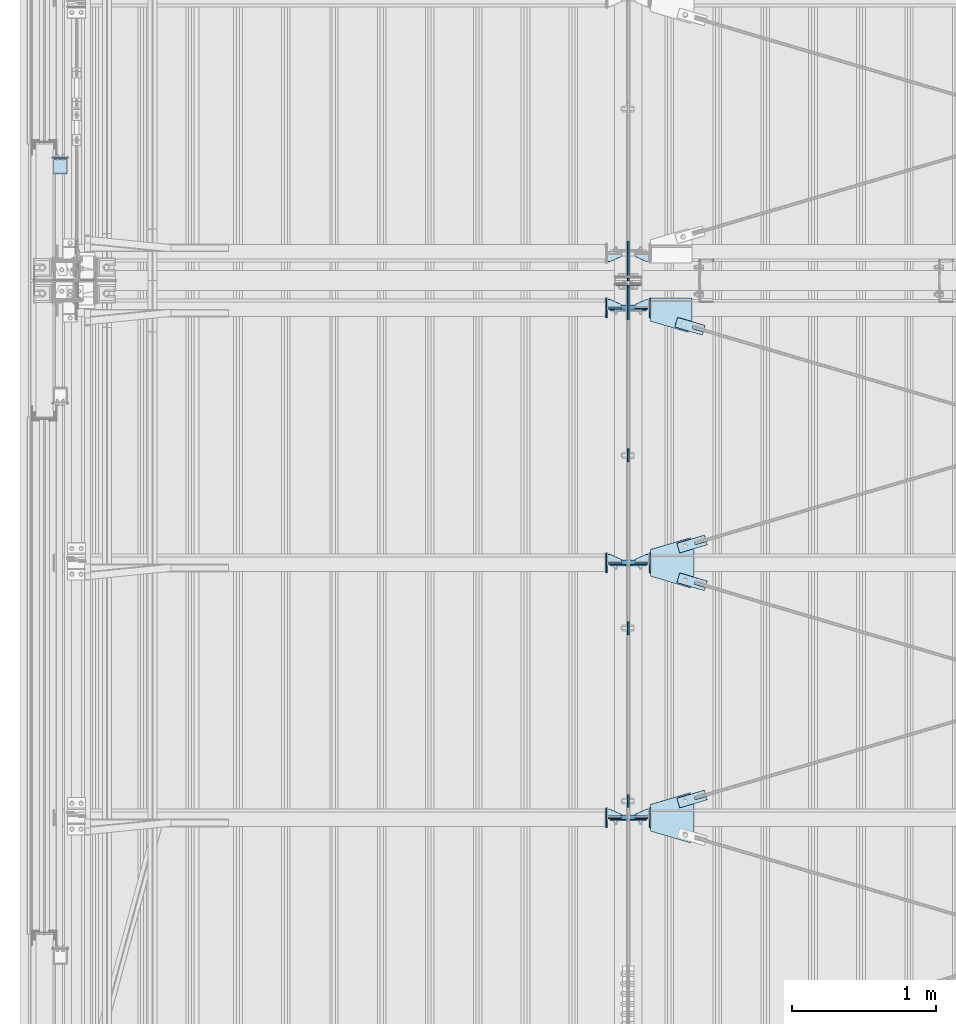
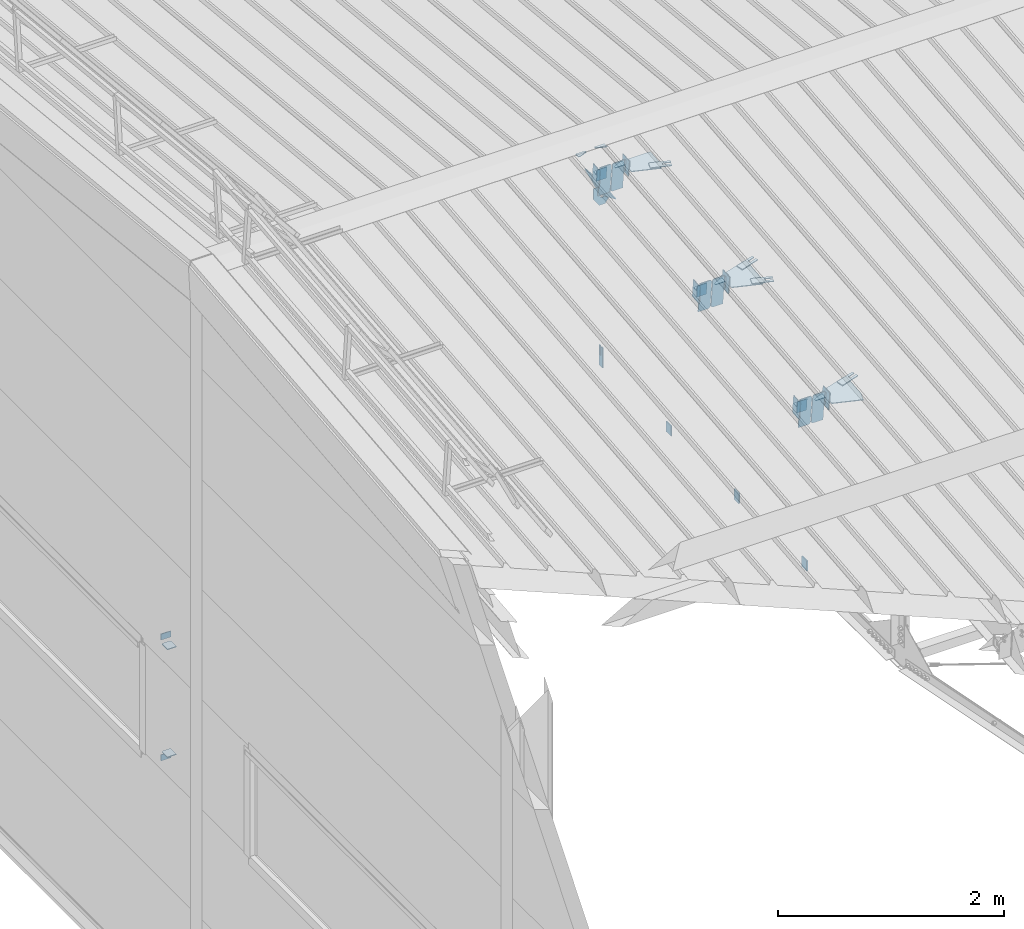
# One storey, part 117 of 709: 44 plates, 4 openings, 21 elements without a shape of their own.
"""IFC4 building model written with IfcOpenShell, lengths in millimetres."""

from ifc_helpers import new_model, si_unit, direction, frame, origin_with_axes, place, context, subcontext, project, spatial, line, indexed_curve, outline, extrude, material, element, aggregate, save


model = new_model("IFC4")

# Units and contexts
model_context = context("Model", 3, precision=0.2, world=origin_with_axes(), true_north=direction((0.0, 1.0)))
body_context = subcontext(model_context, "Body", "Model", "MODEL_VIEW")
ifc_project = project(units=[si_unit("LENGTHUNIT", "METRE", prefix="MILLI"), si_unit("AREAUNIT", "SQUARE_METRE"), si_unit("VOLUMEUNIT", "CUBIC_METRE"), si_unit("MASSUNIT", "GRAM", prefix="KILO"), si_unit("TIMEUNIT", "SECOND"), si_unit("PLANEANGLEUNIT", "RADIAN"), si_unit("SOLIDANGLEUNIT", "STERADIAN"), si_unit("THERMODYNAMICTEMPERATUREUNIT", "DEGREE_CELSIUS"), si_unit("LUMINOUSINTENSITYUNIT", "LUMEN")], contexts=[model_context])

# Site, building, storey
site_placement = place(None, origin_with_axes())
site = spatial("IfcSite", under=ifc_project, at=site_placement, CompositionType="ELEMENT")
building_placement = place(site_placement, origin_with_axes())
building = spatial("IfcBuilding", under=site, at=building_placement, Name="Undefined", CompositionType="ELEMENT")
storey_placement = place(building_placement, origin_with_axes())
storey = spatial("IfcBuildingStorey", under=building, at=storey_placement, Name="Undefined", CompositionType="ELEMENT", Elevation=0.0)

# Assembly, plates
assembly_1_placement = place(storey_placement, frame((4000.0, 346.0, 7089.70002), z_axis=(1.0, 0.0, 0.0), x_axis=(0.0, 0.9950371902, 0.099503719)))
assembly_1 = element("IfcElementAssembly", 1, at=assembly_1_placement, inside=storey)
ifc_material = material(Name="C355-6", Category="STEEL")
plate_1_placement = place(assembly_1_placement, frame((6951.14662, 163.0, -127.0), z_axis=(1.0, 0.0, 0.0), x_axis=(0.0, 0.0, 1.0)))
plate_1 = element("IfcPlate", 2, at=plate_1_placement, material=ifc_material, ObjectType="585", context=body_context, shape_type="SolidModel", body=[
    extrude(outline(indexed_curve([(0.0, 0.0), (108.0, 0.0), (123.0, 15.0), (123.0, 311.0), (108.0, 326.0), (0.0, 326.0)], segments=[line(1, 2, 3, 4, 5, 6, 1)])), frame((0.0, 0.0, 4.0), z_axis=(0.0, 0.0, 1.0), x_axis=(1.0, 0.0, 0.0)), (0.0, 0.0, -1.0), 8.0),
])
plate_2_placement = place(assembly_1_placement, frame((10515.43997, 163.0, 127.0), z_axis=(-1.0, 0.0, 0.0), x_axis=(0.0, 0.0, -1.0)))
plate_2 = element("IfcPlate", 3, at=plate_2_placement, material=ifc_material, ObjectType="589", context=body_context, shape_type="SolidModel", body=[
    extrude(outline(indexed_curve([(0.0, 0.0), (108.0, 0.0), (123.0, 15.0), (123.0, 311.0), (108.0, 326.0), (0.0, 326.0)], segments=[line(1, 2, 3, 4, 5, 6, 1)])), frame((0.0, 0.0, 4.0), z_axis=(0.0, 0.0, 1.0), x_axis=(1.0, 0.0, 0.0)), (0.0, 0.0, -1.0), 8.0),
])
plate_3_placement = place(assembly_1_placement, frame((10515.436, 163.0, -127.0), z_axis=(1.0, 0.0, 0.0), x_axis=(0.0, 0.0, 1.0)))
plate_3 = element("IfcPlate", 4, at=plate_3_placement, material=ifc_material, ObjectType="585", context=body_context, shape_type="SolidModel", body=[
    extrude(outline(indexed_curve([(0.0, 0.0), (108.0, 0.0), (123.0, 15.0), (123.0, 311.0), (108.0, 326.0), (0.0, 326.0)], segments=[line(1, 2, 3, 4, 5, 6, 1)])), frame((0.0, 0.0, 4.0), z_axis=(0.0, 0.0, 1.0), x_axis=(1.0, 0.0, 0.0)), (0.0, 0.0, -1.0), 8.0),
])
plate_4_placement = place(assembly_1_placement, frame((8733.29528, 163.0, 127.0), z_axis=(-1.0, 0.0, 0.0), x_axis=(0.0, 0.0, -1.0)))
plate_4 = element("IfcPlate", 5, at=plate_4_placement, material=ifc_material, ObjectType="585", context=body_context, shape_type="SolidModel", body=[
    extrude(outline(indexed_curve([(0.0, 0.0), (108.0, 0.0), (123.0, 15.0), (123.0, 311.0), (108.0, 326.0), (0.0, 326.0)], segments=[line(1, 2, 3, 4, 5, 6, 1)])), frame((0.0, 0.0, 4.0), z_axis=(0.0, 0.0, 1.0), x_axis=(1.0, 0.0, 0.0)), (0.0, 0.0, -1.0), 8.0),
])
plate_5_placement = place(assembly_1_placement, frame((8733.29131, 163.0, -127.0), z_axis=(1.0, 0.0, 0.0), x_axis=(0.0, 0.0, 1.0)))
plate_5 = element("IfcPlate", 6, at=plate_5_placement, material=ifc_material, ObjectType="585", context=body_context, shape_type="SolidModel", body=[
    extrude(outline(indexed_curve([(0.0, 0.0), (108.0, 0.0), (123.0, 15.0), (123.0, 311.0), (108.0, 326.0), (0.0, 326.0)], segments=[line(1, 2, 3, 4, 5, 6, 1)])), frame((0.0, 0.0, 4.0), z_axis=(0.0, 0.0, 1.0), x_axis=(1.0, 0.0, 0.0)), (0.0, 0.0, -1.0), 8.0),
])
plate_6_placement = place(assembly_1_placement, frame((6951.15059, 163.0, 127.0), z_axis=(-1.0, 0.0, 0.0), x_axis=(0.0, 0.0, -1.0)))
plate_6 = element("IfcPlate", 7, at=plate_6_placement, material=ifc_material, ObjectType="585", context=body_context, shape_type="SolidModel", body=[
    extrude(outline(indexed_curve([(0.0, 0.0), (108.0, 0.0), (123.0, 15.0), (123.0, 311.0), (108.0, 326.0), (0.0, 326.0)], segments=[line(1, 2, 3, 4, 5, 6, 1)])), frame((0.0, 0.0, 4.0), z_axis=(0.0, 0.0, 1.0), x_axis=(1.0, 0.0, 0.0)), (0.0, 0.0, -1.0), 8.0),
])
plate_7_placement = place(assembly_1_placement, frame((10651.77731, -302.35483, 0.0), z_axis=(0.0, 0.0, 1.0), x_axis=(0.099503719, 0.9950371902, 0.0)))
plate_7 = element("IfcPlate", 8, at=plate_7_placement, material=ifc_material, ObjectType="439", context=body_context, shape_type="SolidModel", body=[
    extrude(outline(indexed_curve([(0.0, 0.0), (130.0, 0.0), (105.12407, 248.7593)], segments=[line(1, 2, 3, 1)])), frame((0.0, 0.0, 6.0), z_axis=(0.0, 0.0, 1.0), x_axis=(1.0, 0.0, 0.0)), (0.0, 0.0, -1.0), 12.0),
])
aggregate(assembly_1, [plate_1, plate_2, plate_3, plate_4, plate_5, plate_6, plate_7])

# Assembly, plate
assembly_2_placement = place(storey_placement, frame((4000.0, 21654.0, 7089.70002), z_axis=(-1.0, 0.0, 0.0), x_axis=(0.0, -0.9950371902, 0.099503719)))
assembly_2 = element("IfcElementAssembly", 9, at=assembly_2_placement, inside=storey)
plate_8_placement = place(assembly_2_placement, frame((10651.77731, -302.35483, 0.0), z_axis=(0.0, 0.0, 1.0), x_axis=(0.099503719, 0.9950371902, 0.0)))
plate_8 = element("IfcPlate", 10, at=plate_8_placement, material=ifc_material, ObjectType="439", context=body_context, shape_type="SolidModel", body=[
    extrude(outline(indexed_curve([(0.0, 0.0), (130.0, 0.0), (105.12407, 248.7593)], segments=[line(1, 2, 3, 1)])), frame((0.0, 0.0, 6.0), z_axis=(0.0, 0.0, 1.0), x_axis=(1.0, 0.0, 0.0)), (0.0, 0.0, -1.0), 12.0),
])
aggregate(assembly_2, [plate_8])

# Assembly, plates
assembly_3_placement = place(storey_placement, frame((4000.0, 10985.0, 8155.10002), z_axis=(0.0, -1.0, 0.0), x_axis=(0.0, 0.0, -1.0)))
assembly_3 = element("IfcElementAssembly", 11, at=assembly_3_placement, inside=storey)
plate_9_placement = place(assembly_3_placement, frame((2165.1, 0.0, 30.0), z_axis=(0.0, 1.0, 0.0), x_axis=(0.0, 0.0, -1.0)))
plate_9 = element("IfcPlate", 12, at=plate_9_placement, material=ifc_material, ObjectType="441", context=body_context, shape_type="SolidModel", body=[
    extrude(outline(indexed_curve([(0.0, 0.0), (60.0, 0.0), (60.0, 220.0), (41.0, 220.0), (41.0, 120.0), (19.0, 120.0), (19.0, 220.0), (0.0, 220.0)], segments=[line(1, 2, 3, 4, 5, 6, 7, 8, 1)])), frame((0.0, 0.0, 6.0), z_axis=(0.0, 0.0, 1.0), x_axis=(1.0, 0.0, 0.0)), (0.0, 0.0, -1.0), 12.0),
])
plate_10_placement = place(assembly_3_placement, frame((206.36285, -87.0, 14.0), z_axis=(0.0, 0.0, -1.0), x_axis=(0.0, 1.0, 0.0)))
plate_10 = element("IfcPlate", 13, at=plate_10_placement, material=ifc_material, ObjectType="440", context=body_context, shape_type="SolidModel", body=[
    extrude(outline(indexed_curve([(0.0, 0.0), (71.0, 0.0), (71.0, 120.0), (103.0, 120.0), (103.0, 0.0), (174.0, 0.0), (174.0, 120.0), (117.0, 200.0), (57.0, 200.0), (0.0, 120.0)], segments=[line(1, 2, 3, 4, 5, 6, 7, 8, 9, 10, 1)])), frame((0.0, 0.0, 4.0), z_axis=(0.0, 0.0, 1.0), x_axis=(1.0, 0.0, 0.0)), (0.0, 0.0, -1.0), 8.0),
])
aggregate(assembly_3, [plate_9, plate_10])

# Assembly, plate
assembly_4_placement = place(storey_placement, frame((4000.0, 7334.75, 6100.00002), z_axis=(-1.0, 0.0, 0.0), x_axis=(0.0, 1.0, 0.0)))
assembly_4 = element("IfcElementAssembly", 14, at=assembly_4_placement, inside=storey)
plate_11_placement = place(assembly_4_placement, origin_with_axes())
plate_11 = element("IfcPlate", 15, at=plate_11_placement, material=ifc_material, ObjectType="491", context=body_context, shape_type="SolidModel", body=[
    extrude(outline(indexed_curve([(0.0, 0.0), (90.0, 0.0), (90.0, 110.0), (0.0, 110.0)], segments=[line(1, 2, 3, 4, 1)])), frame((0.0, 0.0, 6.0), z_axis=(0.0, 0.0, 1.0), x_axis=(1.0, 0.0, 0.0)), (0.0, 0.0, -1.0), 12.0),
])
aggregate(assembly_4, [plate_11])

assembly_5_placement = place(storey_placement, frame((4000.0, 8536.5, 6100.00002), z_axis=(-1.0, 0.0, 0.0), x_axis=(0.0, 1.0, 0.0)))
assembly_5 = element("IfcElementAssembly", 16, at=assembly_5_placement, inside=storey)
plate_12_placement = place(assembly_5_placement, origin_with_axes())
plate_12 = element("IfcPlate", 17, at=plate_12_placement, material=ifc_material, ObjectType="491", context=body_context, shape_type="SolidModel", body=[
    extrude(outline(indexed_curve([(0.0, 0.0), (90.0, 0.0), (90.0, 110.0), (0.0, 110.0)], segments=[line(1, 2, 3, 4, 1)])), frame((0.0, 0.0, 6.0), z_axis=(0.0, 0.0, 1.0), x_axis=(1.0, 0.0, 0.0)), (0.0, 0.0, -1.0), 12.0),
])
aggregate(assembly_5, [plate_12])

assembly_6_placement = place(storey_placement, frame((4000.0, 9738.25, 6100.00002), z_axis=(-1.0, 0.0, 0.0), x_axis=(0.0, 1.0, 0.0)))
assembly_6 = element("IfcElementAssembly", 18, at=assembly_6_placement, inside=storey)
plate_13_placement = place(assembly_6_placement, origin_with_axes())
plate_13 = element("IfcPlate", 19, at=plate_13_placement, material=ifc_material, ObjectType="491", context=body_context, shape_type="SolidModel", body=[
    extrude(outline(indexed_curve([(0.0, 0.0), (90.0, 0.0), (90.0, 110.0), (0.0, 110.0)], segments=[line(1, 2, 3, 4, 1)])), frame((0.0, 0.0, 6.0), z_axis=(0.0, 0.0, 1.0), x_axis=(1.0, 0.0, 0.0)), (0.0, 0.0, -1.0), 12.0),
])
aggregate(assembly_6, [plate_13])

assembly_7_placement = place(storey_placement, frame((50.0, 16500.0, 2550.0), z_axis=(0.0, 0.0, -1.0), x_axis=(0.0, -1.0, 0.0)))
assembly_7 = element("IfcElementAssembly", 20, at=assembly_7_placement, inside=storey)
plate_14_placement = place(assembly_7_placement, frame((4646.0, 50.0, -50.0), z_axis=(-1.0, 0.0, 0.0), x_axis=(0.0, 0.0, -1.0)))
plate_14 = element("IfcPlate", 21, at=plate_14_placement, material=ifc_material, ObjectType="509", context=body_context, shape_type="SolidModel", body=[
    extrude(outline(indexed_curve([(0.0, 0.0), (65.0, 0.0), (65.0, 100.0), (0.0, 100.0)], segments=[line(1, 2, 3, 4, 1)])), frame((0.0, 0.0, 4.0), z_axis=(0.0, 0.0, 1.0), x_axis=(1.0, 0.0, 0.0)), (0.0, 0.0, -1.0), 8.0),
])
aggregate(assembly_7, [plate_14])

assembly_8_placement = place(storey_placement, frame((50.0, 16500.0, 4020.0), z_axis=(0.0, 0.0, -1.0), x_axis=(0.0, -1.0, 0.0)))
assembly_8 = element("IfcElementAssembly", 22, at=assembly_8_placement, inside=storey)
plate_15_placement = place(assembly_8_placement, frame((4646.0, -50.0, 50.0), z_axis=(-1.0, 0.0, 0.0), x_axis=(0.0, 0.0, 1.0)))
plate_15 = element("IfcPlate", 23, at=plate_15_placement, material=ifc_material, ObjectType="509", context=body_context, shape_type="SolidModel", body=[
    extrude(outline(indexed_curve([(0.0, 0.0), (65.0, 0.0), (65.0, 100.0), (0.0, 100.0)], segments=[line(1, 2, 3, 4, 1)])), frame((0.0, 0.0, 4.0), z_axis=(0.0, 0.0, 1.0), x_axis=(1.0, 0.0, 0.0)), (0.0, 0.0, -1.0), 8.0),
])
aggregate(assembly_8, [plate_15])

# Assembly, plates
assembly_9_placement = place(storey_placement, frame((50.0, 11800.0, 2600.0), z_axis=(0.0, -1.0, 0.0), x_axis=(0.0, 0.0, 1.0)))
assembly_9 = element("IfcElementAssembly", 24, at=assembly_9_placement, inside=storey)
plate_16_placement = place(assembly_9_placement, frame((1267.0, -46.0, -46.0), z_axis=(1.0, 0.0, 0.0), x_axis=(0.0, 1.0, 0.0)))
plate_16 = element("IfcPlate", 25, at=plate_16_placement, material=ifc_material, ObjectType="510", context=body_context, shape_type="SolidModel", body=[
    extrude(outline(indexed_curve([(0.0, 10.0), (10.0, 0.0), (82.0, 0.0), (92.0, 10.0), (92.0, 104.0), (0.0, 104.0)], segments=[line(1, 2, 3, 4, 5, 6, 1)])), frame((0.0, 0.0, 4.0), z_axis=(0.0, 0.0, 1.0), x_axis=(1.0, 0.0, 0.0)), (0.0, 0.0, -1.0), 8.0),
])
plate_17_placement = place(assembly_9_placement, frame((103.0, 46.0, -46.0), z_axis=(-1.0, 0.0, 0.0), x_axis=(0.0, -1.0, 0.0)))
plate_17 = element("IfcPlate", 26, at=plate_17_placement, material=ifc_material, ObjectType="510", context=body_context, shape_type="SolidModel", body=[
    extrude(outline(indexed_curve([(0.0, 10.0), (10.0, 0.0), (82.0, 0.0), (92.0, 10.0), (92.0, 104.0), (0.0, 104.0)], segments=[line(1, 2, 3, 4, 5, 6, 1)])), frame((0.0, 0.0, 4.0), z_axis=(0.0, 0.0, 1.0), x_axis=(1.0, 0.0, 0.0)), (0.0, 0.0, -1.0), 8.0),
])
aggregate(assembly_9, [plate_16, plate_17])

# Assembly, plate, voiding feature
assembly_10_placement = place(storey_placement, frame((4000.0, 7262.55385, 7862.7594), z_axis=(0.2847296511, -0.9538504697, -0.095385047), x_axis=(0.9586078582, 0.2833165921, 0.028331659)))
assembly_10 = element("IfcElementAssembly", 27, at=assembly_10_placement, inside=storey)
plate_18_placement = place(assembly_10_placement, frame((363.68279, 0.0, -35.0), z_axis=(0.0, 1.0, 0.0), x_axis=(0.0, 0.0, 1.0)))
plate_18 = element("IfcPlate", 28, at=plate_18_placement, material=ifc_material, ObjectType="574", context=body_context, shape_type="SolidModel", body=[
    extrude(outline(indexed_curve([(0.0, 0.0), (70.0, 0.0), (70.0, 200.0), (0.0, 200.0)], segments=[line(1, 2, 3, 4, 1)])), frame((0.0, 0.0, 4.0), z_axis=(0.0, 0.0, 1.0), x_axis=(1.0, 0.0, 0.0)), (0.0, 0.0, -1.0), 8.0),
])
voiding_feature_1_placement = place(plate_18_placement, frame((24.0, 120.0, 0.0), z_axis=(0.0, 0.0, 1.0), x_axis=(1.0, 0.0, 0.0)))
element("IfcVoidingFeature", 29, at=voiding_feature_1_placement, cuts=plate_18, Name="PLATE", PredefinedType="HOLE", context=body_context, shape_type="SolidModel", body=[
    extrude(outline(indexed_curve([(0.0, 0.0), (22.0, 0.0), (22.0, 85.0), (0.0, 85.0)], segments=[line(1, 2, 3, 4, 1)])), frame((0.0, 0.0, 6.5), z_axis=(0.0, 0.0, 1.0), x_axis=(1.0, 0.0, 0.0)), (0.0, 0.0, -1.0), 13.0),
])
aggregate(assembly_10, [plate_18])

assembly_11_placement = place(storey_placement, frame((4000.0, 9035.85409, 8040.08943), z_axis=(-0.2847296511, -0.9538504697, -0.095385047), x_axis=(0.9586078582, -0.2833165921, -0.028331659)))
assembly_11 = element("IfcElementAssembly", 30, at=assembly_11_placement, inside=storey)
plate_19_placement = place(assembly_11_placement, frame((363.68279, 0.0, -35.0), z_axis=(0.0, 1.0, 0.0), x_axis=(0.0, 0.0, 1.0)))
plate_19 = element("IfcPlate", 31, at=plate_19_placement, material=ifc_material, ObjectType="574", context=body_context, shape_type="SolidModel", body=[
    extrude(outline(indexed_curve([(0.0, 0.0), (70.0, 0.0), (70.0, 200.0), (0.0, 200.0)], segments=[line(1, 2, 3, 4, 1)])), frame((0.0, 0.0, 4.0), z_axis=(0.0, 0.0, 1.0), x_axis=(1.0, 0.0, 0.0)), (0.0, 0.0, -1.0), 8.0),
])
voiding_feature_2_placement = place(plate_19_placement, frame((24.0, 120.0, 0.0), z_axis=(0.0, 0.0, 1.0), x_axis=(1.0, 0.0, 0.0)))
element("IfcVoidingFeature", 32, at=voiding_feature_2_placement, cuts=plate_19, Name="PLATE", PredefinedType="HOLE", context=body_context, shape_type="SolidModel", body=[
    extrude(outline(indexed_curve([(0.0, 0.0), (22.0, 0.0), (22.0, 85.0), (0.0, 85.0)], segments=[line(1, 2, 3, 4, 1)])), frame((0.0, 0.0, 6.5), z_axis=(0.0, 0.0, 1.0), x_axis=(1.0, 0.0, 0.0)), (0.0, 0.0, -1.0), 13.0),
])
aggregate(assembly_11, [plate_19])

assembly_12_placement = place(storey_placement, frame((4000.0, 9035.85409, 8040.08943), z_axis=(0.2847296511, -0.9538504697, -0.095385047), x_axis=(0.9586078582, 0.2833165921, 0.028331659)))
assembly_12 = element("IfcElementAssembly", 33, at=assembly_12_placement, inside=storey)
plate_20_placement = place(assembly_12_placement, frame((363.68279, 0.0, -35.0), z_axis=(0.0, 1.0, 0.0), x_axis=(0.0, 0.0, 1.0)))
plate_20 = element("IfcPlate", 34, at=plate_20_placement, material=ifc_material, ObjectType="574", context=body_context, shape_type="SolidModel", body=[
    extrude(outline(indexed_curve([(0.0, 0.0), (70.0, 0.0), (70.0, 200.0), (0.0, 200.0)], segments=[line(1, 2, 3, 4, 1)])), frame((0.0, 0.0, 4.0), z_axis=(0.0, 0.0, 1.0), x_axis=(1.0, 0.0, 0.0)), (0.0, 0.0, -1.0), 8.0),
])
voiding_feature_3_placement = place(plate_20_placement, frame((24.0, 120.0, 0.0), z_axis=(0.0, 0.0, 1.0), x_axis=(1.0, 0.0, 0.0)))
element("IfcVoidingFeature", 35, at=voiding_feature_3_placement, cuts=plate_20, Name="PLATE", PredefinedType="HOLE", context=body_context, shape_type="SolidModel", body=[
    extrude(outline(indexed_curve([(0.0, 0.0), (22.0, 0.0), (22.0, 85.0), (0.0, 85.0)], segments=[line(1, 2, 3, 4, 1)])), frame((0.0, 0.0, 6.5), z_axis=(0.0, 0.0, 1.0), x_axis=(1.0, 0.0, 0.0)), (0.0, 0.0, -1.0), 13.0),
])
aggregate(assembly_12, [plate_20])

assembly_13_placement = place(storey_placement, frame((4000.0, 10809.15434, 8217.41945), z_axis=(-0.2847296511, -0.9538504697, -0.095385047), x_axis=(0.9586078582, -0.2833165921, -0.028331659)))
assembly_13 = element("IfcElementAssembly", 36, at=assembly_13_placement, inside=storey)
plate_21_placement = place(assembly_13_placement, frame((348.68279, 0.0, -35.0), z_axis=(0.0, 1.0, 0.0), x_axis=(0.0, 0.0, 1.0)))
plate_21 = element("IfcPlate", 37, at=plate_21_placement, material=ifc_material, ObjectType="574", context=body_context, shape_type="SolidModel", body=[
    extrude(outline(indexed_curve([(0.0, 0.0), (70.0, 0.0), (70.0, 200.0), (0.0, 200.0)], segments=[line(1, 2, 3, 4, 1)])), frame((0.0, 0.0, 4.0), z_axis=(0.0, 0.0, 1.0), x_axis=(1.0, 0.0, 0.0)), (0.0, 0.0, -1.0), 8.0),
])
voiding_feature_4_placement = place(plate_21_placement, frame((24.0, 120.0, 0.0), z_axis=(0.0, 0.0, 1.0), x_axis=(1.0, 0.0, 0.0)))
element("IfcVoidingFeature", 38, at=voiding_feature_4_placement, cuts=plate_21, Name="PLATE", PredefinedType="HOLE", context=body_context, shape_type="SolidModel", body=[
    extrude(outline(indexed_curve([(0.0, 0.0), (22.0, 0.0), (22.0, 85.0), (0.0, 85.0)], segments=[line(1, 2, 3, 4, 1)])), frame((0.0, 0.0, 6.5), z_axis=(0.0, 0.0, 1.0), x_axis=(1.0, 0.0, 0.0)), (0.0, 0.0, -1.0), 13.0),
])
aggregate(assembly_13, [plate_21])

# Assembly, plates
assembly_14_placement = place(storey_placement, frame((0.0, 7263.34988, 7854.7592), z_axis=(0.0, 0.9950371902, 0.099503719), x_axis=(1.0, 0.0, 0.0)))
assembly_14 = element("IfcElementAssembly", 39, at=assembly_14_placement, inside=storey)
plate_22_placement = place(assembly_14_placement, frame((3953.0, 65.0, 0.0), z_axis=(0.0, 0.0, 1.0), x_axis=(-1.0, 0.0, 0.0)))
plate_22 = element("IfcPlate", 40, at=plate_22_placement, material=ifc_material, ObjectType="587", context=body_context, shape_type="SolidModel", body=[
    extrude(outline(indexed_curve([(0.0, 0.0), (100.0, 0.0), (100.0, 130.0), (0.0, 130.0)], segments=[line(1, 2, 3, 4, 1)])), frame((0.0, 0.0, 4.0), z_axis=(0.0, 0.0, 1.0), x_axis=(1.0, 0.0, 0.0)), (0.0, 0.0, -1.0), 8.0),
])
plate_23_placement = place(assembly_14_placement, frame((3953.0, 0.0, 60.0), z_axis=(0.0, -1.0, 0.0), x_axis=(-1.0, 0.0, 0.0)))
plate_23 = element("IfcPlate", 41, at=plate_23_placement, material=ifc_material, ObjectType="588", context=body_context, shape_type="SolidModel", body=[
    extrude(outline(indexed_curve([(0.0, 36.0), (80.0, 0.0), (100.0, 0.0), (100.0, 56.0), (0.0, 56.0)], segments=[line(1, 2, 3, 4, 5, 1)])), frame((0.0, 0.0, 4.0), z_axis=(0.0, 0.0, 1.0), x_axis=(1.0, 0.0, 0.0)), (0.0, 0.0, -1.0), 8.0),
])
plate_24_placement = place(assembly_14_placement, frame((3849.0, -98.0, 60.0), z_axis=(1.0, 0.0, 0.0), x_axis=(0.0, 0.0, -1.0)))
plate_24 = element("IfcPlate", 42, at=plate_24_placement, material=ifc_material, ObjectType="586", context=body_context, shape_type="SolidModel", body=[
    extrude(outline(indexed_curve([(0.0, 0.0), (120.0, 0.0), (120.0, 196.0), (0.0, 196.0)], segments=[line(1, 2, 3, 4, 1)])), frame((0.0, 0.0, 4.0), z_axis=(0.0, 0.0, 1.0), x_axis=(1.0, 0.0, 0.0)), (0.0, 0.0, -1.0), 8.0),
])
aggregate(assembly_14, [plate_22, plate_23, plate_24])

assembly_15_placement = place(storey_placement, frame((0.0, 9036.65012, 8032.08923), z_axis=(0.0, 0.9950371902, 0.099503719), x_axis=(1.0, 0.0, 0.0)))
assembly_15 = element("IfcElementAssembly", 43, at=assembly_15_placement, inside=storey)
plate_25_placement = place(assembly_15_placement, frame((3953.0, 0.0, 60.0), z_axis=(0.0, -1.0, 0.0), x_axis=(-1.0, 0.0, 0.0)))
plate_25 = element("IfcPlate", 44, at=plate_25_placement, material=ifc_material, ObjectType="588", context=body_context, shape_type="SolidModel", body=[
    extrude(outline(indexed_curve([(0.0, 36.0), (80.0, 0.0), (100.0, 0.0), (100.0, 56.0), (0.0, 56.0)], segments=[line(1, 2, 3, 4, 5, 1)])), frame((0.0, 0.0, 4.0), z_axis=(0.0, 0.0, 1.0), x_axis=(1.0, 0.0, 0.0)), (0.0, 0.0, -1.0), 8.0),
])
plate_26_placement = place(assembly_15_placement, frame((3849.0, -98.0, 60.0), z_axis=(1.0, 0.0, 0.0), x_axis=(0.0, 0.0, -1.0)))
plate_26 = element("IfcPlate", 45, at=plate_26_placement, material=ifc_material, ObjectType="586", context=body_context, shape_type="SolidModel", body=[
    extrude(outline(indexed_curve([(0.0, 0.0), (120.0, 0.0), (120.0, 196.0), (0.0, 196.0)], segments=[line(1, 2, 3, 4, 1)])), frame((0.0, 0.0, 4.0), z_axis=(0.0, 0.0, 1.0), x_axis=(1.0, 0.0, 0.0)), (0.0, 0.0, -1.0), 8.0),
])
plate_27_placement = place(assembly_15_placement, frame((3953.0, 65.0, 0.0), z_axis=(0.0, 0.0, 1.0), x_axis=(-1.0, 0.0, 0.0)))
plate_27 = element("IfcPlate", 46, at=plate_27_placement, material=ifc_material, ObjectType="587", context=body_context, shape_type="SolidModel", body=[
    extrude(outline(indexed_curve([(0.0, 0.0), (100.0, 0.0), (100.0, 130.0), (0.0, 130.0)], segments=[line(1, 2, 3, 4, 1)])), frame((0.0, 0.0, 4.0), z_axis=(0.0, 0.0, 1.0), x_axis=(1.0, 0.0, 0.0)), (0.0, 0.0, -1.0), 8.0),
])
aggregate(assembly_15, [plate_25, plate_26, plate_27])

assembly_16_placement = place(storey_placement, frame((0.0, 10809.95037, 8209.41925), z_axis=(0.0, 0.9950371902, 0.099503719), x_axis=(1.0, 0.0, 0.0)))
assembly_16 = element("IfcElementAssembly", 47, at=assembly_16_placement, inside=storey)
plate_28_placement = place(assembly_16_placement, frame((3953.0, 0.0, 60.0), z_axis=(0.0, -1.0, 0.0), x_axis=(-1.0, 0.0, 0.0)))
plate_28 = element("IfcPlate", 48, at=plate_28_placement, material=ifc_material, ObjectType="588", context=body_context, shape_type="SolidModel", body=[
    extrude(outline(indexed_curve([(0.0, 36.0), (80.0, 0.0), (100.0, 0.0), (100.0, 56.0), (0.0, 56.0)], segments=[line(1, 2, 3, 4, 5, 1)])), frame((0.0, 0.0, 4.0), z_axis=(0.0, 0.0, 1.0), x_axis=(1.0, 0.0, 0.0)), (0.0, 0.0, -1.0), 8.0),
])
plate_29_placement = place(assembly_16_placement, frame((3953.0, 65.0, 0.0), z_axis=(0.0, 0.0, 1.0), x_axis=(-1.0, 0.0, 0.0)))
plate_29 = element("IfcPlate", 49, at=plate_29_placement, material=ifc_material, ObjectType="587", context=body_context, shape_type="SolidModel", body=[
    extrude(outline(indexed_curve([(0.0, 0.0), (100.0, 0.0), (100.0, 130.0), (0.0, 130.0)], segments=[line(1, 2, 3, 4, 1)])), frame((0.0, 0.0, 4.0), z_axis=(0.0, 0.0, 1.0), x_axis=(1.0, 0.0, 0.0)), (0.0, 0.0, -1.0), 8.0),
])
plate_30_placement = place(assembly_16_placement, frame((3849.0, -98.0, 60.0), z_axis=(1.0, 0.0, 0.0), x_axis=(0.0, 0.0, -1.0)))
plate_30 = element("IfcPlate", 50, at=plate_30_placement, material=ifc_material, ObjectType="586", context=body_context, shape_type="SolidModel", body=[
    extrude(outline(indexed_curve([(0.0, 0.0), (120.0, 0.0), (120.0, 196.0), (0.0, 196.0)], segments=[line(1, 2, 3, 4, 1)])), frame((0.0, 0.0, 4.0), z_axis=(0.0, 0.0, 1.0), x_axis=(1.0, 0.0, 0.0)), (0.0, 0.0, -1.0), 8.0),
])
aggregate(assembly_16, [plate_28, plate_29, plate_30])

# Assembly, plate
assembly_17_placement = place(storey_placement, frame((4000.0, 11190.04963, 8209.41925), z_axis=(0.0, -0.9950371902, 0.099503719), x_axis=(-1.0, 0.0, 0.0)))
assembly_17 = element("IfcElementAssembly", 51, at=assembly_17_placement, inside=storey)
plate_31_placement = place(assembly_17_placement, frame((47.0, 0.0, 60.0), z_axis=(0.0, 1.0, 0.0), x_axis=(1.0, 0.0, 0.0)))
plate_31 = element("IfcPlate", 52, at=plate_31_placement, material=ifc_material, ObjectType="588", context=body_context, shape_type="SolidModel", body=[
    extrude(outline(indexed_curve([(0.0, 36.0), (80.0, 0.0), (100.0, 0.0), (100.0, 56.0), (0.0, 56.0)], segments=[line(1, 2, 3, 4, 5, 1)])), frame((0.0, 0.0, 4.0), z_axis=(0.0, 0.0, 1.0), x_axis=(1.0, 0.0, 0.0)), (0.0, 0.0, -1.0), 8.0),
])
aggregate(assembly_17, [plate_31])

# Assembly, plates
assembly_18_placement = place(storey_placement, frame((4000.0, 7263.34988, 7854.7991), z_axis=(0.0, 0.9950371902, 0.099503719), x_axis=(1.0, 0.0, 0.0)))
assembly_18 = element("IfcElementAssembly", 53, at=assembly_18_placement, inside=storey)
plate_32_placement = place(assembly_18_placement, frame((154.99945, 0.0, 92.98165), z_axis=(0.0, -1.0, 0.0), x_axis=(0.0, 0.0, -1.0)))
plate_32 = element("IfcPlate", 54, at=plate_32_placement, material=ifc_material, ObjectType="576", context=body_context, shape_type="SolidModel", body=[
    extrude(outline(indexed_curve([(0.0, 0.0), (185.9633, 0.0), (268.14324, 276.67769), (181.86854, 302.30336), (4.09476, 302.30336), (-82.17995, 276.67769)], segments=[line(1, 2, 3, 4, 5, 6, 1)])), frame((0.0, 0.0, 4.0), z_axis=(0.0, 0.0, 1.0), x_axis=(1.0, 0.0, 0.0)), (0.0, 0.0, -1.0), 8.0),
])
plate_33_placement = place(assembly_18_placement, frame((47.0, -65.0, 0.0), z_axis=(0.0, 0.0, 1.0), x_axis=(1.0, 0.0, 0.0)))
plate_33 = element("IfcPlate", 55, at=plate_33_placement, material=ifc_material, ObjectType="587", context=body_context, shape_type="SolidModel", body=[
    extrude(outline(indexed_curve([(0.0, 0.0), (100.0, 0.0), (100.0, 130.0), (0.0, 130.0)], segments=[line(1, 2, 3, 4, 1)])), frame((0.0, 0.0, 4.0), z_axis=(0.0, 0.0, 1.0), x_axis=(1.0, 0.0, 0.0)), (0.0, 0.0, -1.0), 8.0),
])
plate_34_placement = place(assembly_18_placement, frame((47.0, 0.0, 60.0), z_axis=(0.0, 1.0, 0.0), x_axis=(1.0, 0.0, 0.0)))
plate_34 = element("IfcPlate", 56, at=plate_34_placement, material=ifc_material, ObjectType="588", context=body_context, shape_type="SolidModel", body=[
    extrude(outline(indexed_curve([(0.0, 36.0), (80.0, 0.0), (100.0, 0.0), (100.0, 56.0), (0.0, 56.0)], segments=[line(1, 2, 3, 4, 5, 1)])), frame((0.0, 0.0, 4.0), z_axis=(0.0, 0.0, 1.0), x_axis=(1.0, 0.0, 0.0)), (0.0, 0.0, -1.0), 8.0),
])
plate_35_placement = place(assembly_18_placement, frame((151.0, -98.0, -60.0), z_axis=(-1.0, 0.0, 0.0), x_axis=(0.0, 0.0, 1.0)))
plate_35 = element("IfcPlate", 57, at=plate_35_placement, material=ifc_material, ObjectType="586", context=body_context, shape_type="SolidModel", body=[
    extrude(outline(indexed_curve([(0.0, 0.0), (120.0, 0.0), (120.0, 196.0), (0.0, 196.0)], segments=[line(1, 2, 3, 4, 1)])), frame((0.0, 0.0, 4.0), z_axis=(0.0, 0.0, 1.0), x_axis=(1.0, 0.0, 0.0)), (0.0, 0.0, -1.0), 8.0),
])
aggregate(assembly_18, [plate_32, plate_33, plate_34, plate_35])

assembly_19_placement = place(storey_placement, frame((4000.0, 9036.65012, 8032.12913), z_axis=(0.0, 0.9950371902, 0.099503719), x_axis=(1.0, 0.0, 0.0)))
assembly_19 = element("IfcElementAssembly", 58, at=assembly_19_placement, inside=storey)
plate_36_placement = place(assembly_19_placement, frame((151.0, -98.0, -60.0), z_axis=(-1.0, 0.0, 0.0), x_axis=(0.0, 0.0, 1.0)))
plate_36 = element("IfcPlate", 59, at=plate_36_placement, material=ifc_material, ObjectType="586", context=body_context, shape_type="SolidModel", body=[
    extrude(outline(indexed_curve([(0.0, 0.0), (120.0, 0.0), (120.0, 196.0), (0.0, 196.0)], segments=[line(1, 2, 3, 4, 1)])), frame((0.0, 0.0, 4.0), z_axis=(0.0, 0.0, 1.0), x_axis=(1.0, 0.0, 0.0)), (0.0, 0.0, -1.0), 8.0),
])
plate_37_placement = place(assembly_19_placement, frame((47.0, 0.0, 60.0), z_axis=(0.0, 1.0, 0.0), x_axis=(1.0, 0.0, 0.0)))
plate_37 = element("IfcPlate", 60, at=plate_37_placement, material=ifc_material, ObjectType="588", context=body_context, shape_type="SolidModel", body=[
    extrude(outline(indexed_curve([(0.0, 36.0), (80.0, 0.0), (100.0, 0.0), (100.0, 56.0), (0.0, 56.0)], segments=[line(1, 2, 3, 4, 5, 1)])), frame((0.0, 0.0, 4.0), z_axis=(0.0, 0.0, 1.0), x_axis=(1.0, 0.0, 0.0)), (0.0, 0.0, -1.0), 8.0),
])
plate_38_placement = place(assembly_19_placement, frame((47.0, -65.0, 0.0), z_axis=(0.0, 0.0, 1.0), x_axis=(1.0, 0.0, 0.0)))
plate_38 = element("IfcPlate", 61, at=plate_38_placement, material=ifc_material, ObjectType="587", context=body_context, shape_type="SolidModel", body=[
    extrude(outline(indexed_curve([(0.0, 0.0), (100.0, 0.0), (100.0, 130.0), (0.0, 130.0)], segments=[line(1, 2, 3, 4, 1)])), frame((0.0, 0.0, 4.0), z_axis=(0.0, 0.0, 1.0), x_axis=(1.0, 0.0, 0.0)), (0.0, 0.0, -1.0), 8.0),
])
plate_39_placement = place(assembly_19_placement, frame((154.99945, 0.0, 92.98165), z_axis=(0.0, -1.0, 0.0), x_axis=(0.0, 0.0, -1.0)))
plate_39 = element("IfcPlate", 62, at=plate_39_placement, material=ifc_material, ObjectType="576", context=body_context, shape_type="SolidModel", body=[
    extrude(outline(indexed_curve([(0.0, 0.0), (185.9633, 0.0), (268.14324, 276.67769), (181.86854, 302.30336), (4.09476, 302.30336), (-82.17995, 276.67769)], segments=[line(1, 2, 3, 4, 5, 6, 1)])), frame((0.0, 0.0, 4.0), z_axis=(0.0, 0.0, 1.0), x_axis=(1.0, 0.0, 0.0)), (0.0, 0.0, -1.0), 8.0),
])
aggregate(assembly_19, [plate_36, plate_37, plate_38, plate_39])

assembly_20_placement = place(storey_placement, frame((4000.0, 10808.95533, 8219.40952), z_axis=(0.0, 0.9950371902, 0.099503719), x_axis=(1.0, 0.0, 0.0)))
assembly_20 = element("IfcElementAssembly", 63, at=assembly_20_placement, inside=storey)
plate_40_placement = place(assembly_20_placement, frame((151.0, -88.0, -60.0), z_axis=(-1.0, 0.0, 0.0), x_axis=(0.0, 0.0, 1.0)))
plate_40 = element("IfcPlate", 64, at=plate_40_placement, material=ifc_material, ObjectType="590", context=body_context, shape_type="SolidModel", body=[
    extrude(outline(indexed_curve([(0.0, 0.0), (120.0, 0.0), (120.0, 176.0), (0.0, 176.0)], segments=[line(1, 2, 3, 4, 1)])), frame((0.0, 0.0, 4.0), z_axis=(0.0, 0.0, 1.0), x_axis=(1.0, 0.0, 0.0)), (0.0, 0.0, -1.0), 8.0),
])
plate_41_placement = place(assembly_20_placement, frame((47.0, -65.0, 0.0), z_axis=(0.0, 0.0, 1.0), x_axis=(1.0, 0.0, 0.0)))
plate_41 = element("IfcPlate", 65, at=plate_41_placement, material=ifc_material, ObjectType="587", context=body_context, shape_type="SolidModel", body=[
    extrude(outline(indexed_curve([(0.0, 0.0), (100.0, 0.0), (100.0, 130.0), (0.0, 130.0)], segments=[line(1, 2, 3, 4, 1)])), frame((0.0, 0.0, 4.0), z_axis=(0.0, 0.0, 1.0), x_axis=(1.0, 0.0, 0.0)), (0.0, 0.0, -1.0), 8.0),
])
plate_42_placement = place(assembly_20_placement, frame((47.0, 0.0, 60.0), z_axis=(0.0, 1.0, 0.0), x_axis=(1.0, 0.0, 0.0)))
plate_42 = element("IfcPlate", 66, at=plate_42_placement, material=ifc_material, ObjectType="588", context=body_context, shape_type="SolidModel", body=[
    extrude(outline(indexed_curve([(0.0, 36.0), (80.0, 0.0), (100.0, 0.0), (100.0, 56.0), (0.0, 56.0)], segments=[line(1, 2, 3, 4, 5, 1)])), frame((0.0, 0.0, 4.0), z_axis=(0.0, 0.0, 1.0), x_axis=(1.0, 0.0, 0.0)), (0.0, 0.0, -1.0), 8.0),
])
plate_43_placement = place(assembly_20_placement, frame((442.92369, 10.0, 70.0), z_axis=(0.0, -1.0, 0.0), x_axis=(-1.0, 0.0, 0.0)))
plate_43 = element("IfcPlate", 67, at=plate_43_placement, material=ifc_material, Name="PLATE", ObjectType="577", context=body_context, shape_type="SolidModel", body=[
    extrude(outline(indexed_curve([(0.0, 0.0), (287.92369, 0.0), (287.92369, 162.98181), (25.62567, 240.89065), (0.0, 154.61594)], segments=[line(1, 2, 3, 4, 5, 1)])), frame((0.0, 0.0, 4.0), z_axis=(0.0, 0.0, 1.0), x_axis=(1.0, 0.0, 0.0)), (0.0, 0.0, -1.0), 8.0),
])
aggregate(assembly_20, [plate_40, plate_41, plate_42, plate_43])

# Assembly, plate
assembly_21_placement = place(storey_placement, frame((10000.0, 11191.04467, 8219.40952), z_axis=(0.0, -0.9950371902, 0.099503719), x_axis=(-1.0, 0.0, 0.0)))
assembly_21 = element("IfcElementAssembly", 68, at=assembly_21_placement, inside=storey)
plate_44_placement = place(assembly_21_placement, frame((5953.0, 0.0, 60.0), z_axis=(0.0, -1.0, 0.0), x_axis=(-1.0, 0.0, 0.0)))
plate_44 = element("IfcPlate", 69, at=plate_44_placement, material=ifc_material, ObjectType="588", context=body_context, shape_type="SolidModel", body=[
    extrude(outline(indexed_curve([(0.0, 36.0), (80.0, 0.0), (100.0, 0.0), (100.0, 56.0), (0.0, 56.0)], segments=[line(1, 2, 3, 4, 5, 1)])), frame((0.0, 0.0, 4.0), z_axis=(0.0, 0.0, 1.0), x_axis=(1.0, 0.0, 0.0)), (0.0, 0.0, -1.0), 8.0),
])
aggregate(assembly_21, [plate_44])

save(model, "model.ifc")
